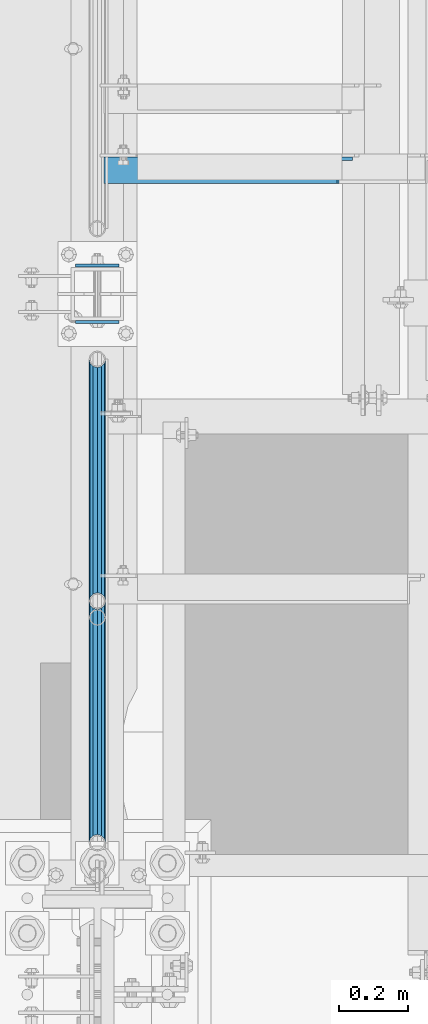
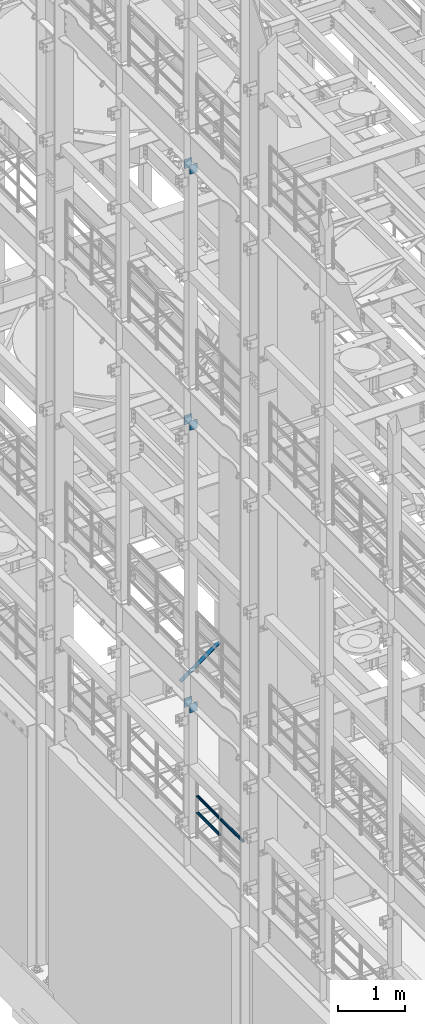
# One storey, part 1247 of 1876: 9 beams, 1 member, 5 elements without a shape of their own.
"""IFC2X3 building model written with IfcOpenShell, lengths in millimetres."""

from ifc_helpers import new_model, si_unit, frame, origin_with_axes, place, context, subcontext, project, spatial, faceted_brep, material, type_object, element, aggregate, save


model = new_model("IFC2X3")

# Units and contexts
model_context = context("Model", 3, precision=1e-05, world=origin_with_axes())
body_context = subcontext(model_context, "Body", "Model", "MODEL_VIEW")
ifc_project = project(units=[si_unit("LENGTHUNIT", "METRE", prefix="MILLI"), si_unit("AREAUNIT", "SQUARE_METRE"), si_unit("VOLUMEUNIT", "CUBIC_METRE"), si_unit("MASSUNIT", "GRAM", prefix="KILO"), si_unit("TIMEUNIT", "SECOND"), si_unit("PLANEANGLEUNIT", "RADIAN"), si_unit("SOLIDANGLEUNIT", "STERADIAN"), si_unit("THERMODYNAMICTEMPERATUREUNIT", "DEGREE_CELSIUS"), si_unit("LUMINOUSINTENSITYUNIT", "LUMEN")], contexts=[model_context])

# Site, building, storey
site_placement = place(None, origin_with_axes())
site = spatial("IfcSite", under=ifc_project, at=site_placement, CompositionType="ELEMENT")
building_placement = place(site_placement, origin_with_axes())
building = spatial("IfcBuilding", under=site, at=building_placement, Name="Undefined", CompositionType="ELEMENT")
storey_placement = place(building_placement, origin_with_axes())
storey = spatial("IfcBuildingStorey", under=building, at=storey_placement, Name="Undefined", CompositionType="ELEMENT", Elevation=0.0)

# Assembly, beams
assembly_1_placement = place(storey_placement, origin_with_axes())
assembly_1 = element("IfcElementAssembly", 1, at=assembly_1_placement, inside=storey, Name="RAIL", AssemblyPlace="NOTDEFINED", PredefinedType="RIGID_FRAME")
ifc_material_1 = material()
beam_type_1 = type_object("IfcBeamType", Name="PIPE1-1/2SCH40", PredefinedType="NOTDEFINED")
beam_1_placement = place(assembly_1_placement, frame((-1.81898940354586e-12, 2665.4125, 5597.525), z_axis=(0.0, 0.0, -1.0), x_axis=(0.0, 1.0, 0.0)))
beam_1 = element("IfcBeam", 2, at=beam_1_placement, type_object=beam_type_1, material=ifc_material_1, Name="RAIL", ObjectType="PIPE1-1/2SCH40", context=body_context, shape_type="Brep", body=[
    faceted_brep([(0.0, 24.1299999999992, 0.0), (12.0650000000064, 20.8971929933177, -12.0649999999987), (12.0650000000064, 20.8971929933177, 12.0649999999987), (12.0650000000064, -20.8971929933177, 12.0649999999987), (12.0650000000064, -20.8971929933177, -12.0649999999987), (0.0, -24.1299999999992, 0.0), (20.8971929933249, -12.0650000000005, 20.8971929933177), (20.8971929933249, -12.0650000000005, 15.8661214311796), (15.2545715621445, -17.7076214311801, 10.2235000000001), (12.5151929933249, -20.4470000000001, 0.0), (15.2545715621445, -17.7076214311801, -10.2235000000001), (20.8971929933249, -12.0650000000005, -15.8661214311796), (20.8971929933249, -12.0650000000005, -20.8971929933177), (24.1300000000063, 0.0, -20.4470000000001), (24.1300000000063, 0.0, -24.130000000001), (21.3906214311868, -10.2235000000001, -17.7076214311819), (21.3906214311868, 10.2235000000001, -17.7076214311819), (20.8971929933249, 12.0650000000005, -15.8661214311796), (20.8971929933249, 12.0650000000005, -20.8971929933177), (15.2545715621445, 17.7076214311801, -10.2235000000001), (12.5151929933249, 20.4470000000001, 0.0), (15.2545715621445, 17.7076214311801, 10.2235000000001), (20.8971929933249, 12.0650000000005, 15.8661214311796), (20.8971929933249, 12.0650000000005, 20.8971929933177), (21.3906214311868, 10.2235000000001, 17.7076214311819), (24.1300000000064, 0.0, 20.4470000000001), (24.1300000000064, 0.0, 24.130000000001), (21.3906214311868, -10.2235000000001, 17.7076214311819), (701.3575, 24.1300000000001, 0.0), (689.2925, 20.8971929933186, -12.0649999999996), (680.460307006681, 12.0649999999996, -20.8971929933186), (701.3575, -24.1299999999919, 0.0), (689.2925, -20.8971929933186, -12.0649999999996), (689.2925, -20.8971929933186, 12.0649999999996), (680.460307006681, -12.0649999999996, 20.8971929933186), (680.460307006681, -12.0649999999996, -20.8971929933186), (677.2275, 0.0, -24.1300000000001), (679.966878568817, 10.2235000000001, -17.7076214311801), (677.2275, 0.0, -20.4470000000001), (680.460307006681, 12.0650000000078, -15.8661214311724), (680.460307006681, -12.0649999999914, -15.8661214311887), (679.966878568822, -10.2235000000001, -17.7076214311801), (686.10292843787, -17.7076214311801, -10.2235000000001), (688.842307006689, -20.4470000000001, 0.0), (686.10292843787, -17.7076214311801, 10.2235000000001), (680.460307006681, -12.0649999999914, 15.8661214311887), (679.966878568822, -10.2235000000001, 17.7076214311801), (677.2275, 0.0, 20.4470000000001), (677.2275, 0.0, 24.1300000000001), (680.460307006681, 12.0649999999996, 20.8971929933186), (689.2925, 20.8971929933186, 12.0649999999996), (680.460307006681, 12.0650000000078, 15.8661214311724), (686.102928437854, 17.7076214311801, 10.2235000000001), (688.842307006673, 20.4470000000001, 0.0), (686.102928437854, 17.7076214311801, -10.2235000000001), (679.966878568817, 10.2235000000001, 17.7076214311801)], [[[0, 1, 2]], [[3, 4, 5]], [[6, 7, 8, 9, 10, 11, 12, 4, 3]], [[13, 14, 12, 11, 15]], [[16, 17, 18, 14, 13]], [[2, 1, 18, 17, 19, 20, 21, 22, 23]], [[23, 22, 24, 25, 26]], [[26, 25, 27, 7, 6]], [[1, 0, 28, 29]], [[18, 1, 29, 30]], [[31, 32, 33]], [[6, 3, 33, 34]], [[3, 5, 31, 33]], [[5, 4, 32, 31]], [[4, 12, 35, 32]], [[12, 14, 36, 35]], [[14, 18, 30, 36]], [[37, 38, 36, 30, 39]], [[40, 35, 36, 38, 41]], [[33, 32, 35, 40, 42, 43, 44, 45, 34]], [[34, 45, 46, 47, 48]], [[26, 6, 34, 48]], [[2, 23, 49, 50]], [[23, 26, 48, 49]], [[0, 2, 50, 28]], [[28, 50, 29]], [[49, 51, 52, 53, 54, 39, 30, 29, 50]], [[48, 47, 55, 51, 49]], [[25, 24, 55, 47]], [[55, 24, 22, 21, 52, 51]], [[21, 20, 53, 52]], [[20, 19, 54, 53]], [[19, 17, 16, 37, 39, 54]], [[16, 13, 38, 37]], [[13, 15, 41, 38]], [[41, 15, 11, 10, 42, 40]], [[10, 9, 43, 42]], [[9, 8, 44, 43]], [[8, 7, 27, 46, 45, 44]], [[27, 25, 47, 46]]]),
])
beam_2_placement = place(assembly_1_placement, frame((-1.81898940354586e-12, 1964.055, 5902.325), z_axis=(0.0, 0.0, -1.0), x_axis=(0.0, 1.0, 0.0)))
beam_2 = element("IfcBeam", 3, at=beam_2_placement, type_object=beam_type_1, material=ifc_material_1, Name="RAIL", ObjectType="PIPE1-1/2SCH40", context=body_context, shape_type="Brep", body=[
    faceted_brep([(0.0, 24.1299999999992, 0.0), (12.0650000000064, 20.8971929933177, -12.0649999999987), (12.0650000000064, 20.8971929933177, 12.0649999999987), (12.0650000000064, -20.8971929933177, 12.0649999999987), (12.0650000000064, -20.8971929933177, -12.0649999999987), (0.0, -24.1299999999992, 0.0), (20.8971929933249, -12.0650000000005, 20.8971929933177), (20.8971929933249, -12.0650000000005, 15.8661214311796), (15.2545715621445, -17.7076214311801, 10.2235000000001), (12.5151929933249, -20.4470000000001, 0.0), (15.2545715621445, -17.7076214311801, -10.2235000000001), (20.8971929933249, -12.0650000000005, -15.8661214311796), (20.8971929933249, -12.0650000000005, -20.8971929933177), (24.1300000000063, 0.0, -20.4470000000001), (24.1300000000063, 0.0, -24.130000000001), (21.3906214311868, -10.2235000000001, -17.7076214311819), (21.3906214311868, 10.2235000000001, -17.7076214311819), (20.8971929933249, 12.0650000000005, -15.8661214311796), (20.8971929933249, 12.0650000000005, -20.8971929933177), (15.2545715621445, 17.7076214311801, -10.2235000000001), (12.5151929933249, 20.4470000000001, 0.0), (15.2545715621445, 17.7076214311801, 10.2235000000001), (20.8971929933249, 12.0650000000005, 15.8661214311796), (20.8971929933249, 12.0650000000005, 20.8971929933177), (21.3906214311868, 10.2235000000001, 17.7076214311819), (24.1300000000064, 0.0, 20.4470000000001), (24.1300000000064, 0.0, 24.130000000001), (21.3906214311868, -10.2235000000001, 17.7076214311819), (701.3575, 24.1300000000001, 0.0), (689.2925, 20.8971929933186, -12.0649999999996), (680.460307006681, 12.0649999999996, -20.8971929933186), (701.3575, -24.1299999999919, 0.0), (689.2925, -20.8971929933186, -12.0649999999996), (689.2925, -20.8971929933186, 12.0649999999996), (680.460307006681, -12.0649999999996, 20.8971929933186), (680.460307006681, -12.0649999999996, -20.8971929933186), (677.2275, 0.0, -24.1300000000001), (679.966878568817, 10.2235000000001, -17.7076214311801), (677.2275, 0.0, -20.4470000000001), (680.460307006681, 12.0650000000078, -15.8661214311724), (680.460307006681, -12.0649999999914, -15.8661214311887), (679.966878568822, -10.2235000000001, -17.7076214311801), (686.10292843787, -17.7076214311801, -10.2235000000001), (688.842307006689, -20.4470000000001, 0.0), (686.10292843787, -17.7076214311801, 10.2235000000001), (680.460307006681, -12.0649999999914, 15.8661214311887), (679.966878568822, -10.2235000000001, 17.7076214311801), (677.2275, 0.0, 20.4470000000001), (677.2275, 0.0, 24.1300000000001), (680.460307006681, 12.0649999999996, 20.8971929933186), (689.2925, 20.8971929933186, 12.0649999999996), (680.460307006681, 12.0650000000078, 15.8661214311724), (686.102928437854, 17.7076214311801, 10.2235000000001), (688.842307006673, 20.4470000000001, 0.0), (686.102928437854, 17.7076214311801, -10.2235000000001), (679.966878568817, 10.2235000000001, 17.7076214311801)], [[[0, 1, 2]], [[3, 4, 5]], [[6, 7, 8, 9, 10, 11, 12, 4, 3]], [[13, 14, 12, 11, 15]], [[16, 17, 18, 14, 13]], [[2, 1, 18, 17, 19, 20, 21, 22, 23]], [[23, 22, 24, 25, 26]], [[26, 25, 27, 7, 6]], [[1, 0, 28, 29]], [[18, 1, 29, 30]], [[31, 32, 33]], [[6, 3, 33, 34]], [[3, 5, 31, 33]], [[5, 4, 32, 31]], [[4, 12, 35, 32]], [[12, 14, 36, 35]], [[14, 18, 30, 36]], [[37, 38, 36, 30, 39]], [[40, 35, 36, 38, 41]], [[33, 32, 35, 40, 42, 43, 44, 45, 34]], [[34, 45, 46, 47, 48]], [[26, 6, 34, 48]], [[2, 23, 49, 50]], [[23, 26, 48, 49]], [[0, 2, 50, 28]], [[28, 50, 29]], [[49, 51, 52, 53, 54, 39, 30, 29, 50]], [[48, 47, 55, 51, 49]], [[25, 24, 55, 47]], [[55, 24, 22, 21, 52, 51]], [[21, 20, 53, 52]], [[20, 19, 54, 53]], [[19, 17, 16, 37, 39, 54]], [[16, 13, 38, 37]], [[13, 15, 41, 38]], [[41, 15, 11, 10, 42, 40]], [[10, 9, 43, 42]], [[9, 8, 44, 43]], [[8, 7, 27, 46, 45, 44]], [[27, 25, 47, 46]]]),
])
beam_3_placement = place(assembly_1_placement, frame((-1.81898940354586e-12, 2665.4125, 5902.325), z_axis=(0.0, 0.0, -1.0), x_axis=(0.0, 1.0, 0.0)))
beam_3 = element("IfcBeam", 4, at=beam_3_placement, type_object=beam_type_1, material=ifc_material_1, Name="RAIL", ObjectType="PIPE1-1/2SCH40", context=body_context, shape_type="Brep", body=[
    faceted_brep([(0.0, 24.1299999999992, 0.0), (12.0650000000064, 20.8971929933177, -12.0649999999987), (12.0650000000064, 20.8971929933177, 12.0649999999987), (12.0650000000064, -20.8971929933177, 12.0649999999987), (12.0650000000064, -20.8971929933177, -12.0649999999987), (0.0, -24.1299999999992, 0.0), (20.8971929933249, -12.0650000000005, 20.8971929933177), (20.8971929933249, -12.0650000000005, 15.8661214311796), (15.2545715621445, -17.7076214311801, 10.2235000000001), (12.5151929933249, -20.4470000000001, 0.0), (15.2545715621445, -17.7076214311801, -10.2235000000001), (20.8971929933249, -12.0650000000005, -15.8661214311796), (20.8971929933249, -12.0650000000005, -20.8971929933177), (24.1300000000063, 0.0, -20.4470000000001), (24.1300000000063, 0.0, -24.130000000001), (21.3906214311868, -10.2235000000001, -17.7076214311819), (21.3906214311868, 10.2235000000001, -17.7076214311819), (20.8971929933249, 12.0650000000005, -15.8661214311796), (20.8971929933249, 12.0650000000005, -20.8971929933177), (15.2545715621445, 17.7076214311801, -10.2235000000001), (12.5151929933249, 20.4470000000001, 0.0), (15.2545715621445, 17.7076214311801, 10.2235000000001), (20.8971929933249, 12.0650000000005, 15.8661214311796), (20.8971929933249, 12.0650000000005, 20.8971929933177), (21.3906214311868, 10.2235000000001, 17.7076214311819), (24.1300000000064, 0.0, 20.4470000000001), (24.1300000000064, 0.0, 24.130000000001), (21.3906214311868, -10.2235000000001, 17.7076214311819), (701.3575, 24.1300000000001, 0.0), (689.2925, 20.8971929933186, -12.0649999999996), (680.460307006681, 12.0649999999996, -20.8971929933186), (701.3575, -24.1299999999919, 0.0), (689.2925, -20.8971929933186, -12.0649999999996), (689.2925, -20.8971929933186, 12.0649999999996), (680.460307006681, -12.0649999999996, 20.8971929933186), (680.460307006681, -12.0649999999996, -20.8971929933186), (677.2275, 0.0, -24.1300000000001), (679.966878568817, 10.2235000000001, -17.7076214311801), (677.2275, 0.0, -20.4470000000001), (680.460307006681, 12.0650000000078, -15.8661214311724), (680.460307006681, -12.0649999999914, -15.8661214311887), (679.966878568822, -10.2235000000001, -17.7076214311801), (686.10292843787, -17.7076214311801, -10.2235000000001), (688.842307006689, -20.4470000000001, 0.0), (686.10292843787, -17.7076214311801, 10.2235000000001), (680.460307006681, -12.0649999999914, 15.8661214311887), (679.966878568822, -10.2235000000001, 17.7076214311801), (677.2275, 0.0, 20.4470000000001), (677.2275, 0.0, 24.1300000000001), (680.460307006681, 12.0649999999996, 20.8971929933186), (689.2925, 20.8971929933186, 12.0649999999996), (680.460307006681, 12.0650000000078, 15.8661214311724), (686.102928437854, 17.7076214311801, 10.2235000000001), (688.842307006673, 20.4470000000001, 0.0), (686.102928437854, 17.7076214311801, -10.2235000000001), (679.966878568817, 10.2235000000001, 17.7076214311801)], [[[0, 1, 2]], [[3, 4, 5]], [[6, 7, 8, 9, 10, 11, 12, 4, 3]], [[13, 14, 12, 11, 15]], [[16, 17, 18, 14, 13]], [[2, 1, 18, 17, 19, 20, 21, 22, 23]], [[23, 22, 24, 25, 26]], [[26, 25, 27, 7, 6]], [[1, 0, 28, 29]], [[18, 1, 29, 30]], [[31, 32, 33]], [[6, 3, 33, 34]], [[3, 5, 31, 33]], [[5, 4, 32, 31]], [[4, 12, 35, 32]], [[12, 14, 36, 35]], [[14, 18, 30, 36]], [[37, 38, 36, 30, 39]], [[40, 35, 36, 38, 41]], [[33, 32, 35, 40, 42, 43, 44, 45, 34]], [[34, 45, 46, 47, 48]], [[26, 6, 34, 48]], [[2, 23, 49, 50]], [[23, 26, 48, 49]], [[0, 2, 50, 28]], [[28, 50, 29]], [[49, 51, 52, 53, 54, 39, 30, 29, 50]], [[48, 47, 55, 51, 49]], [[25, 24, 55, 47]], [[55, 24, 22, 21, 52, 51]], [[21, 20, 53, 52]], [[20, 19, 54, 53]], [[19, 17, 16, 37, 39, 54]], [[16, 13, 38, 37]], [[13, 15, 41, 38]], [[41, 15, 11, 10, 42, 40]], [[10, 9, 43, 42]], [[9, 8, 44, 43]], [[8, 7, 27, 46, 45, 44]], [[27, 25, 47, 46]]]),
])
aggregate(assembly_1, [beam_1, beam_2, beam_3])

assembly_2_placement = place(storey_placement, origin_with_axes())
assembly_2 = element("IfcElementAssembly", 5, at=assembly_2_placement, inside=storey, Name="BEAM", AssemblyPlace="NOTDEFINED", PredefinedType="RIGID_FRAME")
ifc_material_2 = material(Name="STEEL/A36")
beam_type_2 = type_object("IfcBeamType", PredefinedType="NOTDEFINED")
beam_4_placement = place(assembly_2_placement, frame((-63.6296757345187, 3638.55, 7448.54714244377), z_axis=(5.59490000219896e-05, 0.0, -0.999999998434855), x_axis=(0.999999998434855, 0.0, 5.59490000219868e-05)))
beam_4 = element("IfcBeam", 6, at=beam_4_placement, type_object=beam_type_2, material=ifc_material_2, Name="PLATE", context=body_context, shape_type="Brep", body=[
    faceted_brep([(0.0, 4.76249999999982, -82.5499999999993), (0.0, 4.76249999999982, 82.5499999999993), (127.0, 4.76249999999982, 82.5499999999993), (127.0, 4.76249999999982, -82.5499999999993), (0.0, -4.76249999999982, 82.5499999999993), (127.0, -4.76249999999982, 82.5499999999993), (0.0, -4.76249999999982, -82.5499999999993), (127.0, -4.76249999999982, -82.5499999999993)], [[[0, 1, 2, 3]], [[1, 4, 5, 2]], [[4, 6, 7, 5]], [[6, 0, 3, 7]], [[5, 7, 3, 2]], [[6, 4, 1, 0]]]),
])
beam_5_placement = place(assembly_2_placement, frame((-63.6296757345187, 3475.0375, 7448.54714244377), z_axis=(5.59490000219896e-05, 0.0, -0.999999998434855), x_axis=(0.999999998434855, 0.0, 5.59490000219868e-05)))
beam_5 = element("IfcBeam", 7, at=beam_5_placement, type_object=beam_type_2, material=ifc_material_2, Name="PLATE", context=body_context, shape_type="Brep", body=[
    faceted_brep([(0.0, 4.76249999999982, -82.5499999999993), (0.0, 4.76249999999982, 82.5499999999993), (127.0, 4.76249999999982, 82.5499999999993), (127.0, 4.76249999999982, -82.5499999999993), (0.0, -4.76249999999982, 82.5499999999993), (127.0, -4.76249999999982, 82.5499999999993), (0.0, -4.76249999999982, -82.5499999999993), (127.0, -4.76249999999982, -82.5499999999993)], [[[0, 1, 2, 3]], [[1, 4, 5, 2]], [[4, 6, 7, 5]], [[6, 0, 3, 7]], [[5, 7, 3, 2]], [[6, 4, 1, 0]]]),
])
aggregate(assembly_2, [beam_4, beam_5])

assembly_3_placement = place(storey_placement, origin_with_axes())
assembly_3 = element("IfcElementAssembly", 8, at=assembly_3_placement, inside=storey, Name="BEAM", AssemblyPlace="NOTDEFINED", PredefinedType="RIGID_FRAME")
beam_6_placement = place(assembly_3_placement, frame((-63.6315195800257, 3638.55, 12604.7488224823), z_axis=(2.95459999824743e-05, 0.0, -0.999999999563517), x_axis=(0.999999999563517, 0.0, 2.95459999828704e-05)))
beam_6 = element("IfcBeam", 9, at=beam_6_placement, type_object=beam_type_2, material=ifc_material_2, Name="PLATE", context=body_context, shape_type="Brep", body=[
    faceted_brep([(0.0, 4.76249999999982, -82.5499999999993), (0.0, 4.76249999999982, 82.5499999999993), (127.0, 4.76249999999982, 82.5499999999993), (127.0, 4.76249999999982, -82.5499999999993), (0.0, -4.76249999999982, 82.5499999999993), (127.0, -4.76249999999982, 82.5499999999993), (0.0, -4.76249999999982, -82.5499999999993), (127.0, -4.76249999999982, -82.5499999999993)], [[[0, 1, 2, 3]], [[1, 4, 5, 2]], [[4, 6, 7, 5]], [[6, 0, 3, 7]], [[5, 7, 3, 2]], [[6, 4, 1, 0]]]),
])
beam_7_placement = place(assembly_3_placement, frame((-63.6315195800257, 3475.0375, 12604.7488224823), z_axis=(2.95459999824743e-05, 0.0, -0.999999999563517), x_axis=(0.999999999563517, 0.0, 2.95459999828704e-05)))
beam_7 = element("IfcBeam", 10, at=beam_7_placement, type_object=beam_type_2, material=ifc_material_2, Name="PLATE", context=body_context, shape_type="Brep", body=[
    faceted_brep([(0.0, 4.76249999999982, -82.5499999999993), (0.0, 4.76249999999982, 82.5499999999993), (127.0, 4.76249999999982, 82.5499999999993), (127.0, 4.76249999999982, -82.5499999999993), (0.0, -4.76249999999982, 82.5499999999993), (127.0, -4.76249999999982, 82.5499999999993), (0.0, -4.76249999999982, -82.5499999999993), (127.0, -4.76249999999982, -82.5499999999993)], [[[0, 1, 2, 3]], [[1, 4, 5, 2]], [[4, 6, 7, 5]], [[6, 0, 3, 7]], [[5, 7, 3, 2]], [[6, 4, 1, 0]]]),
])
aggregate(assembly_3, [beam_6, beam_7])

assembly_4_placement = place(storey_placement, origin_with_axes())
assembly_4 = element("IfcElementAssembly", 11, at=assembly_4_placement, inside=storey, Name="BEAM", AssemblyPlace="NOTDEFINED", PredefinedType="RIGID_FRAME")
beam_8_placement = place(assembly_4_placement, frame((-63.5, 3638.55, 17278.35), z_axis=(0.0, 0.0, -1.0), x_axis=(1.0, 0.0, 0.0)))
beam_8 = element("IfcBeam", 12, at=beam_8_placement, type_object=beam_type_2, material=ifc_material_2, Name="PLATE", context=body_context, shape_type="Brep", body=[
    faceted_brep([(0.0, 4.76249999999982, -82.5499999999993), (0.0, 4.76249999999982, 82.5499999999993), (127.0, 4.76249999999982, 82.5499999999993), (127.0, 4.76249999999982, -82.5499999999993), (0.0, -4.76249999999982, 82.5499999999993), (127.0, -4.76249999999982, 82.5499999999993), (0.0, -4.76249999999982, -82.5499999999993), (127.0, -4.76249999999982, -82.5499999999993)], [[[0, 1, 2, 3]], [[1, 4, 5, 2]], [[4, 6, 7, 5]], [[6, 0, 3, 7]], [[5, 7, 3, 2]], [[6, 4, 1, 0]]]),
])
beam_9_placement = place(assembly_4_placement, frame((-63.5, 3475.0375, 17278.35), z_axis=(0.0, 0.0, -1.0), x_axis=(1.0, 0.0, 0.0)))
beam_9 = element("IfcBeam", 13, at=beam_9_placement, type_object=beam_type_2, material=ifc_material_2, Name="PLATE", context=body_context, shape_type="Brep", body=[
    faceted_brep([(0.0, 4.76249999999982, -82.5499999999993), (0.0, 4.76249999999982, 82.5499999999993), (127.0, 4.76249999999982, 82.5499999999993), (127.0, 4.76249999999982, -82.5499999999993), (0.0, -4.76249999999982, 82.5499999999993), (127.0, -4.76249999999982, 82.5499999999993), (0.0, -4.76249999999982, -82.5499999999993), (127.0, -4.76249999999982, -82.5499999999993)], [[[0, 1, 2, 3]], [[1, 4, 5, 2]], [[4, 6, 7, 5]], [[6, 0, 3, 7]], [[5, 7, 3, 2]], [[6, 4, 1, 0]]]),
])
aggregate(assembly_4, [beam_8, beam_9])

# Assembly, member
assembly_5_placement = place(storey_placement, origin_with_axes())
assembly_5 = element("IfcElementAssembly", 14, at=assembly_5_placement, inside=storey, AssemblyPlace="NOTDEFINED", PredefinedType="RIGID_FRAME")
member_type = type_object("IfcMemberType", Name="L3X3X3/8", PredefinedType="NOTDEFINED")
member_placement = place(assembly_5_placement, frame((22.1939709589552, 3914.775, 7601.73169287095), z_axis=(0.0, -1.0, 0.0), x_axis=(0.812817140855119, 0.0, 0.582518922896166)))
member = element("IfcMember", 15, at=member_placement, type_object=member_type, material=ifc_material_2, ObjectType="L3X3X3/8", context=body_context, shape_type="Brep", body=[
    faceted_brep([(24.4135476554111, 38.1000000000058, -38.0999999999999), (24.4135476554111, 38.1000000000058, 38.0999999999999), (855.72322987264, 38.1000000000749, 38.0999999999999), (855.72322987264, 38.1000000000749, -38.0999999999999), (24.4135476554093, 28.5750000000053, 38.0999999999999), (855.723229872639, 28.5750000000744, 38.0999999999999), (24.4135476554093, 28.5750000000053, -28.5749999999998), (855.723229872639, 28.5750000000744, -28.5749999999998), (24.4135476553975, -38.1000000000031, -28.5749999999998), (855.723229872628, -38.0999999999331, -28.5749999999998), (24.4135476553975, -38.1000000000031, -38.0999999999999), (855.723229872628, -38.0999999999331, -38.0999999999999)], [[[0, 1, 2, 3]], [[1, 4, 5, 2]], [[4, 6, 7, 5]], [[6, 8, 9, 7]], [[8, 10, 11, 9]], [[10, 0, 3, 11]], [[5, 7, 9, 11, 3, 2]], [[10, 8, 6, 4, 1, 0]]]),
])
aggregate(assembly_5, [member])

save(model, "model.ifc")
